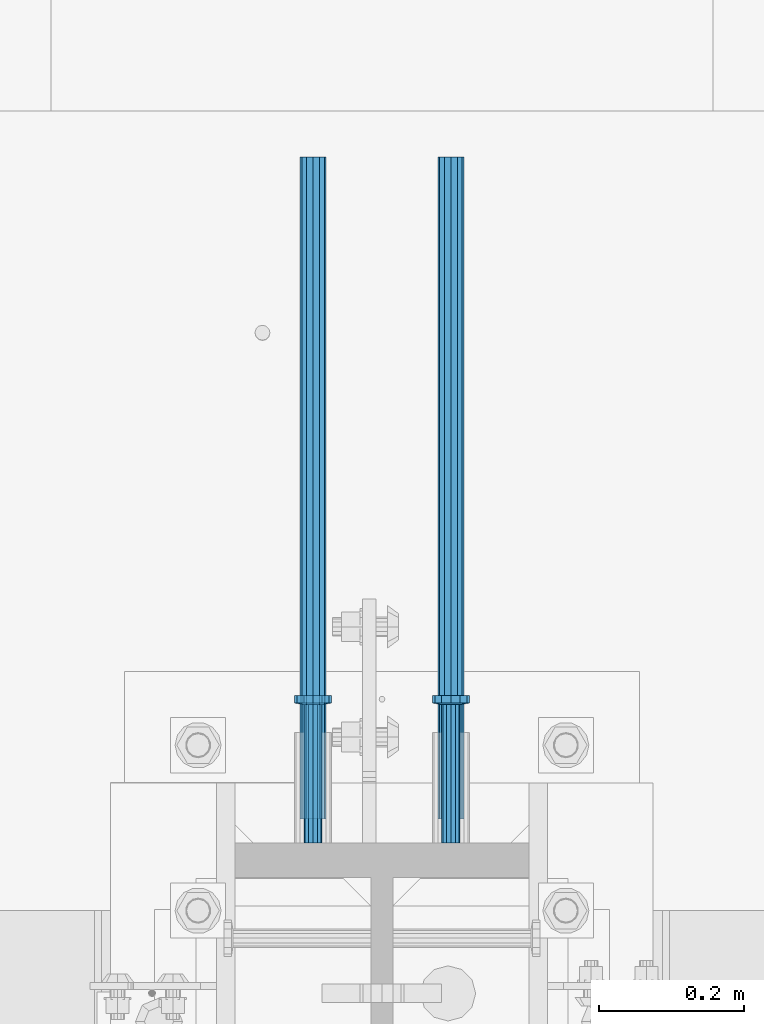
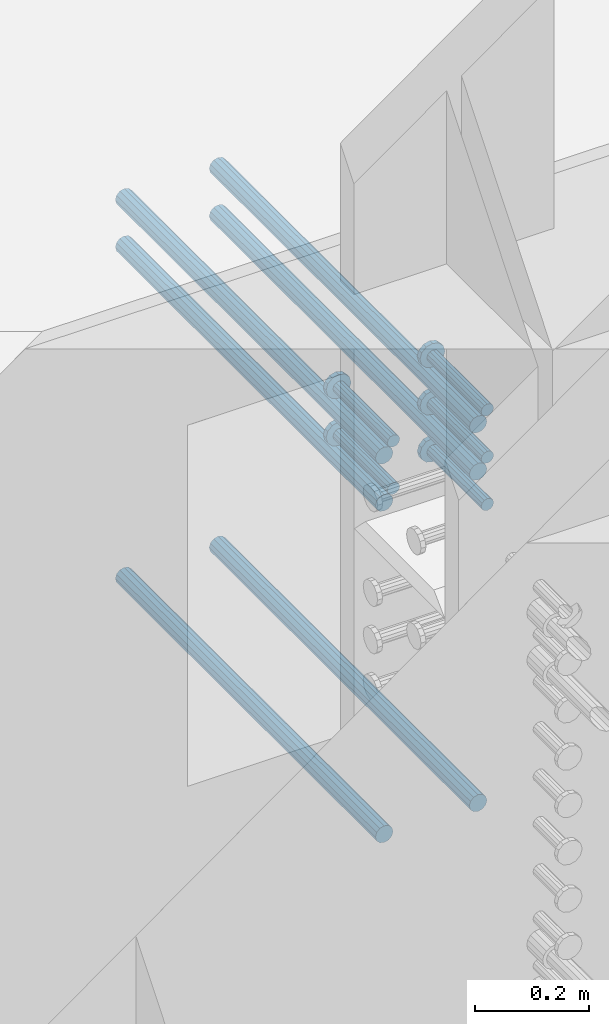
# One storey, part 1322 of 1763: 11 beams, 7 elements without a shape of their own.
"""IFC2X3 building model written with IfcOpenShell, lengths in millimetres."""

from ifc_helpers import new_model, si_unit, frame, origin_with_axes, place, context, subcontext, project, spatial, faceted_brep, material, type_object, element, aggregate, save


model = new_model("IFC2X3")

# Units and contexts
model_context = context("Model", 3, precision=1e-05, world=origin_with_axes())
body_context = subcontext(model_context, "Body", "Model", "MODEL_VIEW")
ifc_project = project(units=[si_unit("LENGTHUNIT", "METRE", prefix="MILLI"), si_unit("AREAUNIT", "SQUARE_METRE"), si_unit("VOLUMEUNIT", "CUBIC_METRE"), si_unit("MASSUNIT", "GRAM", prefix="KILO"), si_unit("TIMEUNIT", "SECOND"), si_unit("PLANEANGLEUNIT", "RADIAN"), si_unit("SOLIDANGLEUNIT", "STERADIAN"), si_unit("THERMODYNAMICTEMPERATUREUNIT", "DEGREE_CELSIUS"), si_unit("LUMINOUSINTENSITYUNIT", "LUMEN")], contexts=[model_context])

# Site, building, storey
site_placement = place(None, origin_with_axes())
site = spatial("IfcSite", under=ifc_project, at=site_placement, CompositionType="ELEMENT")
building_placement = place(site_placement, origin_with_axes())
building = spatial("IfcBuilding", under=site, at=building_placement, Name="Undefined", CompositionType="ELEMENT")
storey_placement = place(building_placement, origin_with_axes())
storey = spatial("IfcBuildingStorey", under=building, at=storey_placement, Name="Undefined", CompositionType="ELEMENT", Elevation=0.0)

# Assembly, beam
assembly_1_placement = place(storey_placement, origin_with_axes())
assembly_1 = element("IfcElementAssembly", 1, at=assembly_1_placement, inside=storey, Name="REBAR", AssemblyPlace="NOTDEFINED", PredefinedType="RIGID_FRAME")
ifc_material_1 = material(Name="STEEL/A706-GR.80")
beam_type_1 = type_object("IfcBeamType", Name="#11 REBAR", PredefinedType="NOTDEFINED")
beam_1_placement = place(assembly_1_placement, frame((-23932.5872736985, 13931.3282483743, 4064.00000000009), z_axis=(0.0, 0.0, 1.0), x_axis=(0.0, 1.0, 0.0)))
beam_1 = element("IfcBeam", 2, at=beam_1_placement, type_object=beam_type_1, material=ifc_material_1, Name="REBAR", ObjectType="#11 REBAR", context=body_context, shape_type="Brep", body=[
    faceted_brep([(0.0, -17.9069999999992, 0.0), (0.0, -15.507916905568, -8.95349999999962), (914.400000001086, -15.507916905568, -8.95349999999962), (914.400000001086, -17.9069999999992, 0.0), (0.0, -8.95349999999962, -15.507916905568), (914.400000001086, -8.95349999999962, -15.507916905568), (0.0, 0.0, -17.9070000000002), (914.400000001086, 0.0, -17.9070000000002), (0.0, 8.95349999999962, -15.507916905568), (914.400000001086, 8.95349999999962, -15.507916905568), (0.0, 15.507916905568, -8.95349999999962), (914.400000001086, 15.507916905568, -8.95349999999962), (0.0, 17.9069999999992, 0.0), (914.400000001086, 17.9069999999992, 0.0), (0.0, 15.507916905568, 8.95349999999962), (914.400000001086, 15.507916905568, 8.95349999999962), (0.0, 8.95349999999962, 15.507916905568), (914.400000001086, 8.95349999999962, 15.507916905568), (0.0, 0.0, 17.9070000000002), (914.400000001086, 0.0, 17.9070000000002), (0.0, -8.95349999999962, 15.507916905568), (914.400000001086, -8.95349999999962, 15.507916905568), (0.0, -15.507916905568, 8.95349999999962), (914.400000001086, -15.507916905568, 8.95349999999962)], [[[0, 1, 2, 3]], [[1, 4, 5, 2]], [[4, 6, 7, 5]], [[6, 8, 9, 7]], [[8, 10, 11, 9]], [[10, 12, 13, 11]], [[12, 14, 15, 13]], [[14, 16, 17, 15]], [[16, 18, 19, 17]], [[18, 20, 21, 19]], [[20, 22, 23, 21]], [[22, 0, 3, 23]], [[5, 7, 9, 11, 13, 15, 17, 19, 21, 23, 3, 2]], [[22, 20, 18, 16, 14, 12, 10, 8, 6, 4, 1, 0]]]),
])
aggregate(assembly_1, [beam_1])

assembly_2_placement = place(storey_placement, origin_with_axes())
assembly_2 = element("IfcElementAssembly", 3, at=assembly_2_placement, inside=storey, Name="REBAR", AssemblyPlace="NOTDEFINED", PredefinedType="RIGID_FRAME")
beam_2_placement = place(assembly_2_placement, frame((-24123.0872736984, 13931.3283171099, 4064.00000000009), z_axis=(0.0, 0.0, 1.0), x_axis=(0.0, 1.0, 0.0)))
beam_2 = element("IfcBeam", 4, at=beam_2_placement, type_object=beam_type_1, material=ifc_material_1, Name="REBAR", ObjectType="#11 REBAR", context=body_context, shape_type="Brep", body=[
    faceted_brep([(0.0, -17.9069999999992, 0.0), (0.0, -15.507916905568, -8.95349999999962), (914.400000001086, -15.507916905568, -8.95349999999962), (914.400000001086, -17.9069999999992, 0.0), (0.0, -8.95349999999962, -15.507916905568), (914.400000001086, -8.95349999999962, -15.507916905568), (0.0, 0.0, -17.9070000000002), (914.400000001086, 0.0, -17.9070000000002), (0.0, 8.95349999999962, -15.507916905568), (914.400000001086, 8.95349999999962, -15.507916905568), (0.0, 15.507916905568, -8.95349999999962), (914.400000001086, 15.507916905568, -8.95349999999962), (0.0, 17.9069999999992, 0.0), (914.400000001086, 17.9069999999992, 0.0), (0.0, 15.507916905568, 8.95349999999962), (914.400000001086, 15.507916905568, 8.95349999999962), (0.0, 8.95349999999962, 15.507916905568), (914.400000001086, 8.95349999999962, 15.507916905568), (0.0, 0.0, 17.9070000000002), (914.400000001086, 0.0, 17.9070000000002), (0.0, -8.95349999999962, 15.507916905568), (914.400000001086, -8.95349999999962, 15.507916905568), (0.0, -15.507916905568, 8.95349999999962), (914.400000001086, -15.507916905568, 8.95349999999962)], [[[0, 1, 2, 3]], [[1, 4, 5, 2]], [[4, 6, 7, 5]], [[6, 8, 9, 7]], [[8, 10, 11, 9]], [[10, 12, 13, 11]], [[12, 14, 15, 13]], [[14, 16, 17, 15]], [[16, 18, 19, 17]], [[18, 20, 21, 19]], [[20, 22, 23, 21]], [[22, 0, 3, 23]], [[5, 7, 9, 11, 13, 15, 17, 19, 21, 23, 3, 2]], [[22, 20, 18, 16, 14, 12, 10, 8, 6, 4, 1, 0]]]),
])
aggregate(assembly_2, [beam_2])

assembly_3_placement = place(storey_placement, origin_with_axes())
assembly_3 = element("IfcElementAssembly", 5, at=assembly_3_placement, inside=storey, Name="REBAR", AssemblyPlace="NOTDEFINED", PredefinedType="RIGID_FRAME")
beam_3_placement = place(assembly_3_placement, frame((-23932.5872736985, 13931.3282483743, 4876.80000000009), z_axis=(0.0, 0.0, 1.0), x_axis=(0.0, 1.0, 0.0)))
beam_3 = element("IfcBeam", 6, at=beam_3_placement, type_object=beam_type_1, material=ifc_material_1, Name="REBAR", ObjectType="#11 REBAR", context=body_context, shape_type="Brep", body=[
    faceted_brep([(0.0, -17.9069999999992, 0.0), (0.0, -15.507916905568, -8.95349999999962), (914.400000001086, -15.507916905568, -8.95349999999962), (914.400000001086, -17.9069999999992, 0.0), (0.0, -8.95349999999962, -15.507916905568), (914.400000001086, -8.95349999999962, -15.507916905568), (0.0, 0.0, -17.9070000000002), (914.400000001086, 0.0, -17.9070000000002), (0.0, 8.95349999999962, -15.507916905568), (914.400000001086, 8.95349999999962, -15.507916905568), (0.0, 15.507916905568, -8.95349999999962), (914.400000001086, 15.507916905568, -8.95349999999962), (0.0, 17.9069999999992, 0.0), (914.400000001086, 17.9069999999992, 0.0), (0.0, 15.507916905568, 8.95349999999962), (914.400000001086, 15.507916905568, 8.95349999999962), (0.0, 8.95349999999962, 15.507916905568), (914.400000001086, 8.95349999999962, 15.507916905568), (0.0, 0.0, 17.9070000000002), (914.400000001086, 0.0, 17.9070000000002), (0.0, -8.95349999999962, 15.507916905568), (914.400000001086, -8.95349999999962, 15.507916905568), (0.0, -15.507916905568, 8.95349999999962), (914.400000001086, -15.507916905568, 8.95349999999962)], [[[0, 1, 2, 3]], [[1, 4, 5, 2]], [[4, 6, 7, 5]], [[6, 8, 9, 7]], [[8, 10, 11, 9]], [[10, 12, 13, 11]], [[12, 14, 15, 13]], [[14, 16, 17, 15]], [[16, 18, 19, 17]], [[18, 20, 21, 19]], [[20, 22, 23, 21]], [[22, 0, 3, 23]], [[5, 7, 9, 11, 13, 15, 17, 19, 21, 23, 3, 2]], [[22, 20, 18, 16, 14, 12, 10, 8, 6, 4, 1, 0]]]),
])
aggregate(assembly_3, [beam_3])

assembly_4_placement = place(storey_placement, origin_with_axes())
assembly_4 = element("IfcElementAssembly", 7, at=assembly_4_placement, inside=storey, Name="REBAR", AssemblyPlace="NOTDEFINED", PredefinedType="RIGID_FRAME")
beam_4_placement = place(assembly_4_placement, frame((-24123.0872736984, 13931.3283171099, 4876.80000000009), z_axis=(0.0, 0.0, 1.0), x_axis=(0.0, 1.0, 0.0)))
beam_4 = element("IfcBeam", 8, at=beam_4_placement, type_object=beam_type_1, material=ifc_material_1, Name="REBAR", ObjectType="#11 REBAR", context=body_context, shape_type="Brep", body=[
    faceted_brep([(0.0, -17.9069999999992, 0.0), (0.0, -15.507916905568, -8.95349999999962), (914.400000001086, -15.507916905568, -8.95349999999962), (914.400000001086, -17.9069999999992, 0.0), (0.0, -8.95349999999962, -15.507916905568), (914.400000001086, -8.95349999999962, -15.507916905568), (0.0, 0.0, -17.9070000000002), (914.400000001086, 0.0, -17.9070000000002), (0.0, 8.95349999999962, -15.507916905568), (914.400000001086, 8.95349999999962, -15.507916905568), (0.0, 15.507916905568, -8.95349999999962), (914.400000001086, 15.507916905568, -8.95349999999962), (0.0, 17.9069999999992, 0.0), (914.400000001086, 17.9069999999992, 0.0), (0.0, 15.507916905568, 8.95349999999962), (914.400000001086, 15.507916905568, 8.95349999999962), (0.0, 8.95349999999962, 15.507916905568), (914.400000001086, 8.95349999999962, 15.507916905568), (0.0, 0.0, 17.9070000000002), (914.400000001086, 0.0, 17.9070000000002), (0.0, -8.95349999999962, 15.507916905568), (914.400000001086, -8.95349999999962, 15.507916905568), (0.0, -15.507916905568, 8.95349999999962), (914.400000001086, -15.507916905568, 8.95349999999962)], [[[0, 1, 2, 3]], [[1, 4, 5, 2]], [[4, 6, 7, 5]], [[6, 8, 9, 7]], [[8, 10, 11, 9]], [[10, 12, 13, 11]], [[12, 14, 15, 13]], [[14, 16, 17, 15]], [[16, 18, 19, 17]], [[18, 20, 21, 19]], [[20, 22, 23, 21]], [[22, 0, 3, 23]], [[5, 7, 9, 11, 13, 15, 17, 19, 21, 23, 3, 2]], [[22, 20, 18, 16, 14, 12, 10, 8, 6, 4, 1, 0]]]),
])
aggregate(assembly_4, [beam_4])

assembly_5_placement = place(storey_placement, origin_with_axes())
assembly_5 = element("IfcElementAssembly", 9, at=assembly_5_placement, inside=storey, Name="REBAR", AssemblyPlace="NOTDEFINED", PredefinedType="RIGID_FRAME")
beam_5_placement = place(assembly_5_placement, frame((-23932.5872736985, 13931.3282483743, 4775.20000000009), z_axis=(0.0, 0.0, 1.0), x_axis=(0.0, 1.0, 0.0)))
beam_5 = element("IfcBeam", 10, at=beam_5_placement, type_object=beam_type_1, material=ifc_material_1, Name="REBAR", ObjectType="#11 REBAR", context=body_context, shape_type="Brep", body=[
    faceted_brep([(0.0, -17.9069999999992, 0.0), (0.0, -15.507916905568, -8.95349999999962), (914.400000001086, -15.507916905568, -8.95349999999962), (914.400000001086, -17.9069999999992, 0.0), (0.0, -8.95349999999962, -15.507916905568), (914.400000001086, -8.95349999999962, -15.507916905568), (0.0, 0.0, -17.9070000000002), (914.400000001086, 0.0, -17.9070000000002), (0.0, 8.95349999999962, -15.507916905568), (914.400000001086, 8.95349999999962, -15.507916905568), (0.0, 15.507916905568, -8.95349999999962), (914.400000001086, 15.507916905568, -8.95349999999962), (0.0, 17.9069999999992, 0.0), (914.400000001086, 17.9069999999992, 0.0), (0.0, 15.507916905568, 8.95349999999962), (914.400000001086, 15.507916905568, 8.95349999999962), (0.0, 8.95349999999962, 15.507916905568), (914.400000001086, 8.95349999999962, 15.507916905568), (0.0, 0.0, 17.9070000000002), (914.400000001086, 0.0, 17.9070000000002), (0.0, -8.95349999999962, 15.507916905568), (914.400000001086, -8.95349999999962, 15.507916905568), (0.0, -15.507916905568, 8.95349999999962), (914.400000001086, -15.507916905568, 8.95349999999962)], [[[0, 1, 2, 3]], [[1, 4, 5, 2]], [[4, 6, 7, 5]], [[6, 8, 9, 7]], [[8, 10, 11, 9]], [[10, 12, 13, 11]], [[12, 14, 15, 13]], [[14, 16, 17, 15]], [[16, 18, 19, 17]], [[18, 20, 21, 19]], [[20, 22, 23, 21]], [[22, 0, 3, 23]], [[5, 7, 9, 11, 13, 15, 17, 19, 21, 23, 3, 2]], [[22, 20, 18, 16, 14, 12, 10, 8, 6, 4, 1, 0]]]),
])
aggregate(assembly_5, [beam_5])

assembly_6_placement = place(storey_placement, origin_with_axes())
assembly_6 = element("IfcElementAssembly", 11, at=assembly_6_placement, inside=storey, Name="REBAR", AssemblyPlace="NOTDEFINED", PredefinedType="RIGID_FRAME")
beam_6_placement = place(assembly_6_placement, frame((-24123.0872736984, 13931.3283171099, 4775.20000000009), z_axis=(0.0, 0.0, 1.0), x_axis=(0.0, 1.0, 0.0)))
beam_6 = element("IfcBeam", 12, at=beam_6_placement, type_object=beam_type_1, material=ifc_material_1, Name="REBAR", ObjectType="#11 REBAR", context=body_context, shape_type="Brep", body=[
    faceted_brep([(0.0, -17.9069999999992, 0.0), (0.0, -15.507916905568, -8.95349999999962), (914.400000001086, -15.507916905568, -8.95349999999962), (914.400000001086, -17.9069999999992, 0.0), (0.0, -8.95349999999962, -15.507916905568), (914.400000001086, -8.95349999999962, -15.507916905568), (0.0, 0.0, -17.9070000000002), (914.400000001086, 0.0, -17.9070000000002), (0.0, 8.95349999999962, -15.507916905568), (914.400000001086, 8.95349999999962, -15.507916905568), (0.0, 15.507916905568, -8.95349999999962), (914.400000001086, 15.507916905568, -8.95349999999962), (0.0, 17.9069999999992, 0.0), (914.400000001086, 17.9069999999992, 0.0), (0.0, 15.507916905568, 8.95349999999962), (914.400000001086, 15.507916905568, 8.95349999999962), (0.0, 8.95349999999962, 15.507916905568), (914.400000001086, 8.95349999999962, 15.507916905568), (0.0, 0.0, 17.9070000000002), (914.400000001086, 0.0, 17.9070000000002), (0.0, -8.95349999999962, 15.507916905568), (914.400000001086, -8.95349999999962, 15.507916905568), (0.0, -15.507916905568, 8.95349999999962), (914.400000001086, -15.507916905568, 8.95349999999962)], [[[0, 1, 2, 3]], [[1, 4, 5, 2]], [[4, 6, 7, 5]], [[6, 8, 9, 7]], [[8, 10, 11, 9]], [[10, 12, 13, 11]], [[12, 14, 15, 13]], [[14, 16, 17, 15]], [[16, 18, 19, 17]], [[18, 20, 21, 19]], [[20, 22, 23, 21]], [[22, 0, 3, 23]], [[5, 7, 9, 11, 13, 15, 17, 19, 21, 23, 3, 2]], [[22, 20, 18, 16, 14, 12, 10, 8, 6, 4, 1, 0]]]),
])
aggregate(assembly_6, [beam_6])

# Assembly, beams
assembly_7_placement = place(storey_placement, origin_with_axes())
assembly_7 = element("IfcElementAssembly", 13, at=assembly_7_placement, inside=storey, Name="COLUMN", AssemblyPlace="NOTDEFINED", PredefinedType="RIGID_FRAME")
ifc_material_2 = material(Name="STEEL/A108")
beam_type_2 = type_object("IfcBeamType", PredefinedType="NOTDEFINED")
beam_7_placement = place(assembly_7_placement, frame((-23932.5872736985, 13898.5624999999, 4927.60000000008), z_axis=(1.0, 0.0, 0.0), x_axis=(0.0, 1.0, 0.0)))
beam_7 = element("IfcBeam", 14, at=beam_7_placement, type_object=beam_type_2, material=ifc_material_2, Name="HEADED STUD ANCHOR", context=body_context, shape_type="Brep", body=[
    faceted_brep([(0.0, -12.6999999999971, -1.81898940354586e-12), (3.63797880709171e-12, -11.0, -6.34999990463257), (191.00799999576, -11.0, -6.34999990454889), (191.007999995752, -12.6999998092651, 8.36735125631094e-11), (7.27595761418343e-12, -6.34999990463257, -11.0), (191.00799999576, -6.34999990463257, -10.9999999999163), (3.63797880709171e-12, 0.0, -12.6999998092651), (191.00799999576, 0.0, -12.6999998091815), (7.27595761418343e-12, 6.34999990463257, -11.0), (191.00799999576, 6.34999990463257, -10.9999999999163), (3.63797880709171e-12, 11.0, -6.34999990463257), (191.00799999576, 11.0, -6.34999990454889), (0.0, 12.6999999999971, -1.81898940354586e-12), (191.007999995752, 12.6999998092651, 8.36735125631094e-11), (0.0, 11.0, 6.34999990463257), (191.007999995752, 11.0, 6.34999990471624), (-3.63797880709171e-12, 6.34999990463257, 11.0), (191.007999995749, 6.34999990463257, 11.0000000000837), (-3.63797880709171e-12, 0.0, 12.6999998092651), (191.007999995749, 0.0, 12.6999998093488), (-3.63797880709171e-12, -6.34999990463257, 11.0), (191.007999995749, -6.34999990463257, 11.0000000000837), (0.0, -11.0, 6.34999990463257), (191.007999995752, -11.0, 6.34999990471624), (193.039999995715, -22.0, -12.6999998091796), (193.039999995708, -25.3999996185303, 8.54925019666553e-11), (193.039999995719, -12.6999998092651, -21.9999999999145), (193.039999995719, 0.0, -25.3999996184448), (193.039999995719, 12.6999998092651, -21.9999999999145), (193.039999995715, 22.0, -12.6999998091796), (193.039999995708, 25.3999996185303, 8.54925019666553e-11), (193.039999995704, 22.0, 12.6999998093506), (193.039999995701, 12.6999998092651, 22.0000000000855), (193.039999995697, 0.0, 25.3999996186158), (193.039999995701, -12.6999998092651, 22.0000000000855), (193.039999995704, -22.0, 12.6999998093506), (203.199999995486, -22.0, -12.6999998091742), (203.199999995482, -25.3999996185303, 9.09494701772928e-11), (203.199999995493, -12.6999998092651, -21.9999999999091), (203.199999995493, 0.0, -25.3999996184393), (203.199999995493, 12.6999998092651, -21.9999999999091), (203.199999995486, 22.0, -12.6999998091742), (203.199999995482, 25.3999996185303, 9.09494701772928e-11), (203.199999995479, 22.0, 12.6999998093561), (203.199999995475, 12.6999998092651, 22.0000000000909), (203.199999995471, 0.0, 25.3999996186212), (203.199999995475, -12.6999998092651, 22.0000000000909), (203.199999995479, -22.0, 12.6999998093561)], [[[0, 1, 2, 3]], [[1, 4, 5, 2]], [[4, 6, 7, 5]], [[6, 8, 9, 7]], [[8, 10, 11, 9]], [[10, 12, 13, 11]], [[12, 14, 15, 13]], [[14, 16, 17, 15]], [[16, 18, 19, 17]], [[18, 20, 21, 19]], [[20, 22, 23, 21]], [[22, 0, 3, 23]], [[22, 20, 18, 16, 14, 12, 10, 8, 6, 4, 1, 0]], [[3, 2, 24, 25]], [[2, 5, 26, 24]], [[5, 7, 27, 26]], [[7, 9, 28, 27]], [[9, 11, 29, 28]], [[11, 13, 30, 29]], [[13, 15, 31, 30]], [[15, 17, 32, 31]], [[17, 19, 33, 32]], [[19, 21, 34, 33]], [[21, 23, 35, 34]], [[23, 3, 25, 35]], [[25, 24, 36, 37]], [[24, 26, 38, 36]], [[26, 27, 39, 38]], [[27, 28, 40, 39]], [[28, 29, 41, 40]], [[29, 30, 42, 41]], [[30, 31, 43, 42]], [[31, 32, 44, 43]], [[32, 33, 45, 44]], [[33, 34, 46, 45]], [[34, 35, 47, 46]], [[35, 25, 37, 47]], [[38, 39, 40, 41, 42, 43, 44, 45, 46, 47, 37, 36]]]),
])
beam_8_placement = place(assembly_7_placement, frame((-24123.0872736984, 13898.5625687355, 4927.60000000008), z_axis=(1.0, 0.0, 0.0), x_axis=(0.0, 1.0, 0.0)))
beam_8 = element("IfcBeam", 15, at=beam_8_placement, type_object=beam_type_2, material=ifc_material_2, Name="HEADED STUD ANCHOR", context=body_context, shape_type="Brep", body=[
    faceted_brep([(0.0, -12.6999999999971, -1.81898940354586e-12), (3.63797880709171e-12, -11.0, -6.34999990463257), (191.00799999576, -11.0, -6.34999990454889), (191.007999995752, -12.6999998092651, 8.36735125631094e-11), (7.27595761418343e-12, -6.34999990463257, -11.0), (191.00799999576, -6.34999990463257, -10.9999999999163), (3.63797880709171e-12, 0.0, -12.6999998092651), (191.00799999576, 0.0, -12.6999998091815), (7.27595761418343e-12, 6.34999990463257, -11.0), (191.00799999576, 6.34999990463257, -10.9999999999163), (3.63797880709171e-12, 11.0, -6.34999990463257), (191.00799999576, 11.0, -6.34999990454889), (0.0, 12.6999999999971, -1.81898940354586e-12), (191.007999995752, 12.6999998092651, 8.36735125631094e-11), (0.0, 11.0, 6.34999990463257), (191.007999995752, 11.0, 6.34999990471624), (-3.63797880709171e-12, 6.34999990463257, 11.0), (191.007999995749, 6.34999990463257, 11.0000000000837), (-3.63797880709171e-12, 0.0, 12.6999998092651), (191.007999995749, 0.0, 12.6999998093488), (-3.63797880709171e-12, -6.34999990463257, 11.0), (191.007999995749, -6.34999990463257, 11.0000000000837), (0.0, -11.0, 6.34999990463257), (191.007999995752, -11.0, 6.34999990471624), (193.039999995715, -22.0, -12.6999998091796), (193.039999995708, -25.3999996185303, 8.54925019666553e-11), (193.039999995719, -12.6999998092651, -21.9999999999145), (193.039999995719, 0.0, -25.3999996184448), (193.039999995719, 12.6999998092651, -21.9999999999145), (193.039999995715, 22.0, -12.6999998091796), (193.039999995708, 25.3999996185303, 8.54925019666553e-11), (193.039999995704, 22.0, 12.6999998093506), (193.039999995701, 12.6999998092651, 22.0000000000855), (193.039999995697, 0.0, 25.3999996186158), (193.039999995701, -12.6999998092651, 22.0000000000855), (193.039999995704, -22.0, 12.6999998093506), (203.199999995486, -22.0, -12.6999998091742), (203.199999995482, -25.3999996185303, 9.09494701772928e-11), (203.199999995493, -12.6999998092651, -21.9999999999091), (203.199999995493, 0.0, -25.3999996184393), (203.199999995493, 12.6999998092651, -21.9999999999091), (203.199999995486, 22.0, -12.6999998091742), (203.199999995482, 25.3999996185303, 9.09494701772928e-11), (203.199999995479, 22.0, 12.6999998093561), (203.199999995475, 12.6999998092651, 22.0000000000909), (203.199999995471, 0.0, 25.3999996186212), (203.199999995475, -12.6999998092651, 22.0000000000909), (203.199999995479, -22.0, 12.6999998093561)], [[[0, 1, 2, 3]], [[1, 4, 5, 2]], [[4, 6, 7, 5]], [[6, 8, 9, 7]], [[8, 10, 11, 9]], [[10, 12, 13, 11]], [[12, 14, 15, 13]], [[14, 16, 17, 15]], [[16, 18, 19, 17]], [[18, 20, 21, 19]], [[20, 22, 23, 21]], [[22, 0, 3, 23]], [[22, 20, 18, 16, 14, 12, 10, 8, 6, 4, 1, 0]], [[3, 2, 24, 25]], [[2, 5, 26, 24]], [[5, 7, 27, 26]], [[7, 9, 28, 27]], [[9, 11, 29, 28]], [[11, 13, 30, 29]], [[13, 15, 31, 30]], [[15, 17, 32, 31]], [[17, 19, 33, 32]], [[19, 21, 34, 33]], [[21, 23, 35, 34]], [[23, 3, 25, 35]], [[25, 24, 36, 37]], [[24, 26, 38, 36]], [[26, 27, 39, 38]], [[27, 28, 40, 39]], [[28, 29, 41, 40]], [[29, 30, 42, 41]], [[30, 31, 43, 42]], [[31, 32, 44, 43]], [[32, 33, 45, 44]], [[33, 34, 46, 45]], [[34, 35, 47, 46]], [[35, 25, 37, 47]], [[38, 39, 40, 41, 42, 43, 44, 45, 46, 47, 37, 36]]]),
])
beam_9_placement = place(assembly_7_placement, frame((-23932.5872736985, 13898.5624312644, 4826.00000000007), z_axis=(1.0, 0.0, 0.0), x_axis=(0.0, 1.0, 0.0)))
beam_9 = element("IfcBeam", 16, at=beam_9_placement, type_object=beam_type_2, material=ifc_material_2, Name="HEADED STUD ANCHOR", context=body_context, shape_type="Brep", body=[
    faceted_brep([(0.0, -12.6999999999971, -1.81898940354586e-12), (3.63797880709171e-12, -11.0, -6.34999990463257), (191.00799999576, -11.0, -6.34999990454889), (191.007999995752, -12.6999998092651, 8.36735125631094e-11), (7.27595761418343e-12, -6.34999990463257, -11.0), (191.00799999576, -6.34999990463257, -10.9999999999163), (3.63797880709171e-12, 0.0, -12.6999998092651), (191.00799999576, 0.0, -12.6999998091815), (7.27595761418343e-12, 6.34999990463257, -11.0), (191.00799999576, 6.34999990463257, -10.9999999999163), (3.63797880709171e-12, 11.0, -6.34999990463257), (191.00799999576, 11.0, -6.34999990454889), (0.0, 12.6999999999971, -1.81898940354586e-12), (191.007999995752, 12.6999998092651, 8.36735125631094e-11), (0.0, 11.0, 6.34999990463257), (191.007999995752, 11.0, 6.34999990471624), (-3.63797880709171e-12, 6.34999990463257, 11.0), (191.007999995749, 6.34999990463257, 11.0000000000837), (-3.63797880709171e-12, 0.0, 12.6999998092651), (191.007999995749, 0.0, 12.6999998093488), (-3.63797880709171e-12, -6.34999990463257, 11.0), (191.007999995749, -6.34999990463257, 11.0000000000837), (0.0, -11.0, 6.34999990463257), (191.007999995752, -11.0, 6.34999990471624), (193.039999995715, -22.0, -12.6999998091796), (193.039999995708, -25.3999996185303, 8.54925019666553e-11), (193.039999995719, -12.6999998092651, -21.9999999999145), (193.039999995719, 0.0, -25.3999996184448), (193.039999995719, 12.6999998092651, -21.9999999999145), (193.039999995715, 22.0, -12.6999998091796), (193.039999995708, 25.3999996185303, 8.54925019666553e-11), (193.039999995704, 22.0, 12.6999998093506), (193.039999995701, 12.6999998092651, 22.0000000000855), (193.039999995697, 0.0, 25.3999996186158), (193.039999995701, -12.6999998092651, 22.0000000000855), (193.039999995704, -22.0, 12.6999998093506), (203.199999995486, -22.0, -12.6999998091742), (203.199999995482, -25.3999996185303, 9.09494701772928e-11), (203.199999995493, -12.6999998092651, -21.9999999999091), (203.199999995493, 0.0, -25.3999996184393), (203.199999995493, 12.6999998092651, -21.9999999999091), (203.199999995486, 22.0, -12.6999998091742), (203.199999995482, 25.3999996185303, 9.09494701772928e-11), (203.199999995479, 22.0, 12.6999998093561), (203.199999995475, 12.6999998092651, 22.0000000000909), (203.199999995471, 0.0, 25.3999996186212), (203.199999995475, -12.6999998092651, 22.0000000000909), (203.199999995479, -22.0, 12.6999998093561)], [[[0, 1, 2, 3]], [[1, 4, 5, 2]], [[4, 6, 7, 5]], [[6, 8, 9, 7]], [[8, 10, 11, 9]], [[10, 12, 13, 11]], [[12, 14, 15, 13]], [[14, 16, 17, 15]], [[16, 18, 19, 17]], [[18, 20, 21, 19]], [[20, 22, 23, 21]], [[22, 0, 3, 23]], [[22, 20, 18, 16, 14, 12, 10, 8, 6, 4, 1, 0]], [[3, 2, 24, 25]], [[2, 5, 26, 24]], [[5, 7, 27, 26]], [[7, 9, 28, 27]], [[9, 11, 29, 28]], [[11, 13, 30, 29]], [[13, 15, 31, 30]], [[15, 17, 32, 31]], [[17, 19, 33, 32]], [[19, 21, 34, 33]], [[21, 23, 35, 34]], [[23, 3, 25, 35]], [[25, 24, 36, 37]], [[24, 26, 38, 36]], [[26, 27, 39, 38]], [[27, 28, 40, 39]], [[28, 29, 41, 40]], [[29, 30, 42, 41]], [[30, 31, 43, 42]], [[31, 32, 44, 43]], [[32, 33, 45, 44]], [[33, 34, 46, 45]], [[34, 35, 47, 46]], [[35, 25, 37, 47]], [[38, 39, 40, 41, 42, 43, 44, 45, 46, 47, 37, 36]]]),
])
beam_10_placement = place(assembly_7_placement, frame((-24123.0872736984, 13898.5625, 4826.00000000007), z_axis=(1.0, 0.0, 0.0), x_axis=(0.0, 1.0, 0.0)))
beam_10 = element("IfcBeam", 17, at=beam_10_placement, type_object=beam_type_2, material=ifc_material_2, Name="HEADED STUD ANCHOR", context=body_context, shape_type="Brep", body=[
    faceted_brep([(0.0, -12.6999999999971, -1.81898940354586e-12), (3.63797880709171e-12, -11.0, -6.34999990463257), (191.00799999576, -11.0, -6.34999990454889), (191.007999995752, -12.6999998092651, 8.36735125631094e-11), (7.27595761418343e-12, -6.34999990463257, -11.0), (191.00799999576, -6.34999990463257, -10.9999999999163), (3.63797880709171e-12, 0.0, -12.6999998092651), (191.00799999576, 0.0, -12.6999998091815), (7.27595761418343e-12, 6.34999990463257, -11.0), (191.00799999576, 6.34999990463257, -10.9999999999163), (3.63797880709171e-12, 11.0, -6.34999990463257), (191.00799999576, 11.0, -6.34999990454889), (0.0, 12.6999999999971, -1.81898940354586e-12), (191.007999995752, 12.6999998092651, 8.36735125631094e-11), (0.0, 11.0, 6.34999990463257), (191.007999995752, 11.0, 6.34999990471624), (-3.63797880709171e-12, 6.34999990463257, 11.0), (191.007999995749, 6.34999990463257, 11.0000000000837), (-3.63797880709171e-12, 0.0, 12.6999998092651), (191.007999995749, 0.0, 12.6999998093488), (-3.63797880709171e-12, -6.34999990463257, 11.0), (191.007999995749, -6.34999990463257, 11.0000000000837), (0.0, -11.0, 6.34999990463257), (191.007999995752, -11.0, 6.34999990471624), (193.039999995715, -22.0, -12.6999998091796), (193.039999995708, -25.3999996185303, 8.54925019666553e-11), (193.039999995719, -12.6999998092651, -21.9999999999145), (193.039999995719, 0.0, -25.3999996184448), (193.039999995719, 12.6999998092651, -21.9999999999145), (193.039999995715, 22.0, -12.6999998091796), (193.039999995708, 25.3999996185303, 8.54925019666553e-11), (193.039999995704, 22.0, 12.6999998093506), (193.039999995701, 12.6999998092651, 22.0000000000855), (193.039999995697, 0.0, 25.3999996186158), (193.039999995701, -12.6999998092651, 22.0000000000855), (193.039999995704, -22.0, 12.6999998093506), (203.199999995486, -22.0, -12.6999998091742), (203.199999995482, -25.3999996185303, 9.09494701772928e-11), (203.199999995493, -12.6999998092651, -21.9999999999091), (203.199999995493, 0.0, -25.3999996184393), (203.199999995493, 12.6999998092651, -21.9999999999091), (203.199999995486, 22.0, -12.6999998091742), (203.199999995482, 25.3999996185303, 9.09494701772928e-11), (203.199999995479, 22.0, 12.6999998093561), (203.199999995475, 12.6999998092651, 22.0000000000909), (203.199999995471, 0.0, 25.3999996186212), (203.199999995475, -12.6999998092651, 22.0000000000909), (203.199999995479, -22.0, 12.6999998093561)], [[[0, 1, 2, 3]], [[1, 4, 5, 2]], [[4, 6, 7, 5]], [[6, 8, 9, 7]], [[8, 10, 11, 9]], [[10, 12, 13, 11]], [[12, 14, 15, 13]], [[14, 16, 17, 15]], [[16, 18, 19, 17]], [[18, 20, 21, 19]], [[20, 22, 23, 21]], [[22, 0, 3, 23]], [[22, 20, 18, 16, 14, 12, 10, 8, 6, 4, 1, 0]], [[3, 2, 24, 25]], [[2, 5, 26, 24]], [[5, 7, 27, 26]], [[7, 9, 28, 27]], [[9, 11, 29, 28]], [[11, 13, 30, 29]], [[13, 15, 31, 30]], [[15, 17, 32, 31]], [[17, 19, 33, 32]], [[19, 21, 34, 33]], [[21, 23, 35, 34]], [[23, 3, 25, 35]], [[25, 24, 36, 37]], [[24, 26, 38, 36]], [[26, 27, 39, 38]], [[27, 28, 40, 39]], [[28, 29, 41, 40]], [[29, 30, 42, 41]], [[30, 31, 43, 42]], [[31, 32, 44, 43]], [[32, 33, 45, 44]], [[33, 34, 46, 45]], [[34, 35, 47, 46]], [[35, 25, 37, 47]], [[38, 39, 40, 41, 42, 43, 44, 45, 46, 47, 37, 36]]]),
])
beam_11_placement = place(assembly_7_placement, frame((-23932.5872736985, 13898.5624312644, 4724.40000000007), z_axis=(1.0, 0.0, 0.0), x_axis=(0.0, 1.0, 0.0)))
beam_11 = element("IfcBeam", 18, at=beam_11_placement, type_object=beam_type_2, material=ifc_material_2, Name="HEADED STUD ANCHOR", context=body_context, shape_type="Brep", body=[
    faceted_brep([(0.0, -12.6999999999971, -1.81898940354586e-12), (3.63797880709171e-12, -11.0, -6.34999990463257), (191.00799999576, -11.0, -6.34999990454889), (191.007999995752, -12.6999998092651, 8.36735125631094e-11), (7.27595761418343e-12, -6.34999990463257, -11.0), (191.00799999576, -6.34999990463257, -10.9999999999163), (3.63797880709171e-12, 0.0, -12.6999998092651), (191.00799999576, 0.0, -12.6999998091815), (7.27595761418343e-12, 6.34999990463257, -11.0), (191.00799999576, 6.34999990463257, -10.9999999999163), (3.63797880709171e-12, 11.0, -6.34999990463257), (191.00799999576, 11.0, -6.34999990454889), (0.0, 12.6999999999971, -1.81898940354586e-12), (191.007999995752, 12.6999998092651, 8.36735125631094e-11), (0.0, 11.0, 6.34999990463257), (191.007999995752, 11.0, 6.34999990471624), (-3.63797880709171e-12, 6.34999990463257, 11.0), (191.007999995749, 6.34999990463257, 11.0000000000837), (-3.63797880709171e-12, 0.0, 12.6999998092651), (191.007999995749, 0.0, 12.6999998093488), (-3.63797880709171e-12, -6.34999990463257, 11.0), (191.007999995749, -6.34999990463257, 11.0000000000837), (0.0, -11.0, 6.34999990463257), (191.007999995752, -11.0, 6.34999990471624), (193.039999995715, -22.0, -12.6999998091796), (193.039999995708, -25.3999996185303, 8.54925019666553e-11), (193.039999995719, -12.6999998092651, -21.9999999999145), (193.039999995719, 0.0, -25.3999996184448), (193.039999995719, 12.6999998092651, -21.9999999999145), (193.039999995715, 22.0, -12.6999998091796), (193.039999995708, 25.3999996185303, 8.54925019666553e-11), (193.039999995704, 22.0, 12.6999998093506), (193.039999995701, 12.6999998092651, 22.0000000000855), (193.039999995697, 0.0, 25.3999996186158), (193.039999995701, -12.6999998092651, 22.0000000000855), (193.039999995704, -22.0, 12.6999998093506), (203.199999995486, -22.0, -12.6999998091742), (203.199999995482, -25.3999996185303, 9.09494701772928e-11), (203.199999995493, -12.6999998092651, -21.9999999999091), (203.199999995493, 0.0, -25.3999996184393), (203.199999995493, 12.6999998092651, -21.9999999999091), (203.199999995486, 22.0, -12.6999998091742), (203.199999995482, 25.3999996185303, 9.09494701772928e-11), (203.199999995479, 22.0, 12.6999998093561), (203.199999995475, 12.6999998092651, 22.0000000000909), (203.199999995471, 0.0, 25.3999996186212), (203.199999995475, -12.6999998092651, 22.0000000000909), (203.199999995479, -22.0, 12.6999998093561)], [[[0, 1, 2, 3]], [[1, 4, 5, 2]], [[4, 6, 7, 5]], [[6, 8, 9, 7]], [[8, 10, 11, 9]], [[10, 12, 13, 11]], [[12, 14, 15, 13]], [[14, 16, 17, 15]], [[16, 18, 19, 17]], [[18, 20, 21, 19]], [[20, 22, 23, 21]], [[22, 0, 3, 23]], [[22, 20, 18, 16, 14, 12, 10, 8, 6, 4, 1, 0]], [[3, 2, 24, 25]], [[2, 5, 26, 24]], [[5, 7, 27, 26]], [[7, 9, 28, 27]], [[9, 11, 29, 28]], [[11, 13, 30, 29]], [[13, 15, 31, 30]], [[15, 17, 32, 31]], [[17, 19, 33, 32]], [[19, 21, 34, 33]], [[21, 23, 35, 34]], [[23, 3, 25, 35]], [[25, 24, 36, 37]], [[24, 26, 38, 36]], [[26, 27, 39, 38]], [[27, 28, 40, 39]], [[28, 29, 41, 40]], [[29, 30, 42, 41]], [[30, 31, 43, 42]], [[31, 32, 44, 43]], [[32, 33, 45, 44]], [[33, 34, 46, 45]], [[34, 35, 47, 46]], [[35, 25, 37, 47]], [[38, 39, 40, 41, 42, 43, 44, 45, 46, 47, 37, 36]]]),
])
aggregate(assembly_7, [beam_7, beam_8, beam_9, beam_10, beam_11])

save(model, "model.ifc")
